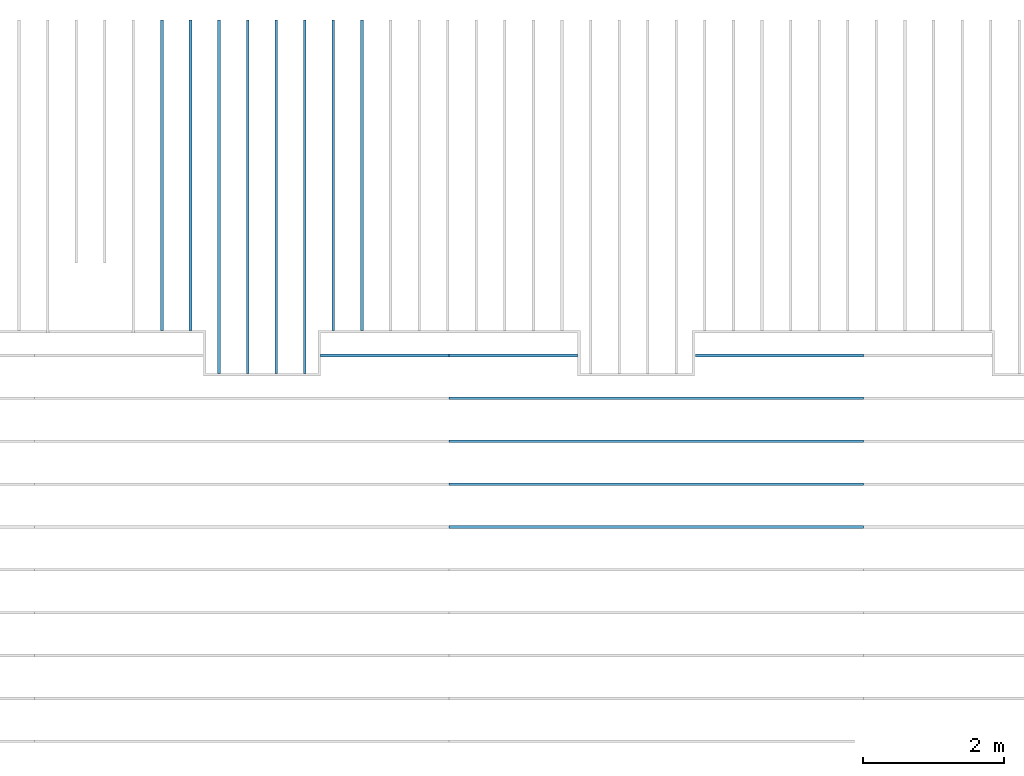
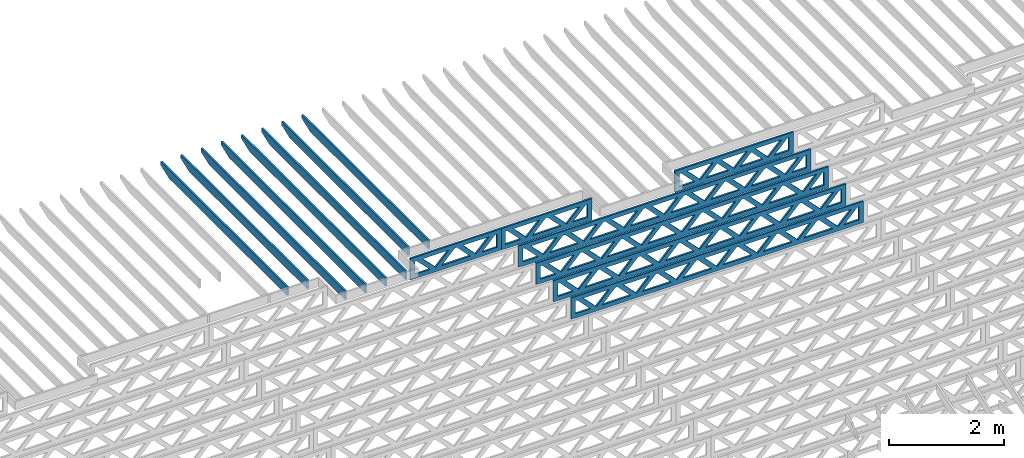
# One storey, part 10 of 18: 15 beams, 3 elements without a shape of their own.
"""IFC4 building model written with IfcOpenShell, lengths in feet."""

from ifc_helpers import new_model, entity, si_unit, converted_unit, derived_unit, direction, frame, frame_2d, origin, origin_2d_with_axis, place, context, subcontext, project, spatial, rectangle, extrude, clip, halfspace, source, transform, mapped, material, material_profile, profile_set, profile_usage, type_object, type_shapes, element, aggregate, save


model = new_model("IFC4")

# Units and contexts
model_context_1 = context("Model", 3, precision=0.0001, world=origin(), true_north=direction((6.12303176911189e-17, 1.0)))
model_context_2 = context("Model", 3, precision=0.0001, world=origin(), true_north=direction((6.12303176911189e-17, 1.0)))
body_context = subcontext(model_context_2, "Body", "Model", "MODEL_VIEW")
ifc_project = project(units=[converted_unit("LENGTHUNIT", "FOOT", entity("IfcRatioMeasure", 0.3048), si_unit("LENGTHUNIT", "METRE"), dimensions=[1, 0, 0, 0, 0, 0, 0]), converted_unit("AREAUNIT", "SQUARE FOOT", entity("IfcRatioMeasure", 0.09290304), si_unit("AREAUNIT", "SQUARE_METRE"), dimensions=[2, 0, 0, 0, 0, 0, 0]), converted_unit("VOLUMEUNIT", "CUBIC FOOT", entity("IfcRatioMeasure", 0.028316846592), si_unit("VOLUMEUNIT", "CUBIC_METRE"), dimensions=[3, 0, 0, 0, 0, 0, 0]), converted_unit("PLANEANGLEUNIT", "DEGREE", entity("IfcRatioMeasure", 0.0174532925199433), si_unit("PLANEANGLEUNIT", "RADIAN"), dimensions=[0, 0, 0, 0, 0, 0, 0]), si_unit("MASSUNIT", "GRAM", prefix="KILO"), derived_unit("MASSDENSITYUNIT", [(si_unit("MASSUNIT", "GRAM", prefix="KILO"), 1), (si_unit("LENGTHUNIT", "METRE"), -3)]), derived_unit("MOMENTOFINERTIAUNIT", [(si_unit("LENGTHUNIT", "METRE"), 4)]), si_unit("TIMEUNIT", "SECOND"), si_unit("FREQUENCYUNIT", "HERTZ"), si_unit("THERMODYNAMICTEMPERATUREUNIT", "DEGREE_CELSIUS"), derived_unit("THERMALTRANSMITTANCEUNIT", [(si_unit("MASSUNIT", "GRAM", prefix="KILO"), 1), (si_unit("THERMODYNAMICTEMPERATUREUNIT", "KELVIN"), -1), (si_unit("TIMEUNIT", "SECOND"), -3)]), derived_unit("VOLUMETRICFLOWRATEUNIT", [(si_unit("LENGTHUNIT", "METRE"), 3), (si_unit("TIMEUNIT", "SECOND"), -1)]), si_unit("ELECTRICCURRENTUNIT", "AMPERE"), si_unit("ELECTRICVOLTAGEUNIT", "VOLT"), si_unit("POWERUNIT", "WATT"), si_unit("FORCEUNIT", "NEWTON"), si_unit("ILLUMINANCEUNIT", "LUX"), si_unit("LUMINOUSFLUXUNIT", "LUMEN"), si_unit("LUMINOUSINTENSITYUNIT", "CANDELA"), derived_unit("USERDEFINED", [(si_unit("MASSUNIT", "GRAM", prefix="KILO"), -1), (si_unit("LENGTHUNIT", "METRE"), -2), (si_unit("TIMEUNIT", "SECOND"), 3), (si_unit("LUMINOUSFLUXUNIT", "LUMEN"), 1)]), derived_unit("LINEARVELOCITYUNIT", [(si_unit("LENGTHUNIT", "METRE"), 1), (si_unit("TIMEUNIT", "SECOND"), -1)]), si_unit("PRESSUREUNIT", "PASCAL"), derived_unit("USERDEFINED", [(si_unit("LENGTHUNIT", "METRE"), -2), (si_unit("MASSUNIT", "GRAM", prefix="KILO"), 1), (si_unit("TIMEUNIT", "SECOND"), -2)]), derived_unit("LINEARFORCEUNIT", [(si_unit("MASSUNIT", "GRAM", prefix="KILO"), 1), (si_unit("LENGTHUNIT", "METRE"), 1), (si_unit("TIMEUNIT", "SECOND"), -2), (si_unit("LENGTHUNIT", "METRE"), -1)]), derived_unit("PLANARFORCEUNIT", [(si_unit("MASSUNIT", "GRAM", prefix="KILO"), 1), (si_unit("LENGTHUNIT", "METRE"), 1), (si_unit("TIMEUNIT", "SECOND"), -2), (si_unit("LENGTHUNIT", "METRE"), -2)])], contexts=[model_context_1])

# Site, building, storey
site_placement = place(None, origin())
site = spatial("IfcSite", under=ifc_project, at=site_placement, CompositionType="ELEMENT")
building_placement = place(site_placement, origin())
building = spatial("IfcBuilding", under=site, at=building_placement, CompositionType="ELEMENT")
storey_placement = place(building_placement, frame((0.0, 0.0, 30.4375000000082)))
storey = spatial("IfcBuildingStorey", under=building, at=storey_placement, Name="ROOF", CompositionType="ELEMENT", Elevation=30.4375000000082)

# Assembly, beam
assembly_1_placement = place(storey_placement, origin())
assembly_1 = element("IfcElementAssembly", 1, at=assembly_1_placement, inside=storey, Name="Structural Beam System:Structural Framing System", ObjectType="Structural Beam System:Structural Framing System", AssemblyPlace="NOTDEFINED", PredefinedType="BEAM_GRID")
ifc_material_1 = material(Name="WOOD TRUSS", Category="Materials")
ifc_material_profile_1 = material_profile(ifc_material_1, rectangle(XDim=1.73473973950632, YDim=0.125, at=origin_2d_with_axis()))
ifc_material_profile_2 = material_profile(ifc_material_1, rectangle(XDim=1.73473973950633, YDim=0.125, at=frame_2d((-1.11022302462516e-16, 0.0), x_axis=(1.0, 0.0))))
ifc_material_profile_3 = material_profile(ifc_material_1, rectangle(XDim=1.73473973950632, YDim=0.125, at=origin_2d_with_axis()))
ifc_material_profile_4 = material_profile(ifc_material_1, rectangle(XDim=1.73473973950633, YDim=0.125, at=origin_2d_with_axis()))
ifc_material_profile_5 = material_profile(ifc_material_1, rectangle(XDim=1.73473973950632, YDim=0.125, at=frame_2d((-5.55111512312578e-17, 0.0), x_axis=(1.0, 0.0))))
ifc_material_profile_6 = material_profile(ifc_material_1, rectangle(XDim=1.73473973950633, YDim=0.125, at=frame_2d((-2.77555756156289e-16, 0.0), x_axis=(1.0, 0.0))))
ifc_material_profile_7 = material_profile(ifc_material_1, rectangle(XDim=1.73473973950632, YDim=0.125, at=frame_2d((-4.9960036108132e-16, 0.0), x_axis=(1.0, 0.0))))
ifc_material_profile_8 = material_profile(ifc_material_1, rectangle(XDim=1.73473973950633, YDim=0.125, at=frame_2d((4.44089209850063e-16, 0.0), x_axis=(1.0, 0.0))))
ifc_material_profile_9 = material_profile(ifc_material_1, rectangle(XDim=1.73473973950632, YDim=0.125, at=origin_2d_with_axis()))
ifc_material_profile_10 = material_profile(ifc_material_1, rectangle(XDim=1.73473973950633, YDim=0.125, at=frame_2d((-4.9960036108132e-16, 0.0), x_axis=(1.0, 0.0))))
ifc_material_profile_11 = material_profile(ifc_material_1, rectangle(XDim=0.291666666666664, YDim=0.125, at=frame_2d((-2.77555756156289e-17, 0.0), x_axis=(1.0, 0.0))))
ifc_material_profile_12 = material_profile(ifc_material_1, rectangle(XDim=0.291666666666628, YDim=0.124999999999995, at=frame_2d((-5.55111512312578e-17, 0.0), x_axis=(1.0, 0.0))))
ifc_material_profile_13 = material_profile(ifc_material_1, rectangle(XDim=0.916666666666666, YDim=0.125000000000003, at=frame_2d((-2.77555756156289e-17, 0.0), x_axis=(1.0, 0.0))))
ifc_material_profile_14 = material_profile(ifc_material_1, rectangle(XDim=0.916666666666651, YDim=0.125, at=frame_2d((-2.77555756156289e-17, 0.0), x_axis=(1.0, 0.0))))
ifc_profile_set_1 = profile_set([ifc_material_profile_1, ifc_material_profile_2, ifc_material_profile_3, ifc_material_profile_4, ifc_material_profile_5, ifc_material_profile_6, ifc_material_profile_7, ifc_material_profile_8, ifc_material_profile_9, ifc_material_profile_10, ifc_material_profile_11, ifc_material_profile_12, ifc_material_profile_13, ifc_material_profile_14])
ifc_profile_usage_1 = profile_usage(ifc_profile_set_1, cardinal=8)
beam_type_1 = type_object("IfcBeamType", PredefinedType="BEAM", material=ifc_profile_set_1)
shared_shape_1 = source(origin(), body_context, "Body", "SweptSolid", [
    extrude(rectangle(XDim=1.73473973950632, YDim=0.125, at=frame_2d((5.55111512312578e-17, 0.0), x_axis=(1.0, 0.0))), frame((1.8533931188195, 0.0, 0.101118361020515), z_axis=(0.720569184836762, 0.0, -0.693383046997606), x_axis=(0.693383046997606, 0.0, 0.720569184836762)), (0.0, 0.0, 1.0), 0.291666666666667),
    extrude(rectangle(XDim=1.73473973950633, YDim=0.125, at=frame_2d((-1.11022302462516e-16, 0.0), x_axis=(1.0, 0.0))), frame((0.603107245146231, 0.0, -0.101118361020454), z_axis=(0.720569184836758, 0.0, 0.69338304699761), x_axis=(0.69338304699761, 0.0, -0.720569184836758)), (0.0, 0.0, 1.0), 0.291666666666667),
    extrude(rectangle(XDim=1.73473973950632, YDim=0.125, at=frame_2d((-5.55111512312578e-17, 0.0), x_axis=(1.0, 0.0))), frame((-0.81327325738963, 0.0, 0.101118361020554), z_axis=(0.720569184836762, 0.0, -0.693383046997606), x_axis=(0.693383046997606, 0.0, 0.720569184836762)), (0.0, 0.0, 1.0), 0.291666666666667),
    extrude(rectangle(XDim=1.73473973950633, YDim=0.125, at=frame_2d((-1.66533453693773e-16, 0.0), x_axis=(1.0, 0.0))), frame((-2.0635591310629, 0.0, -0.101118361020415), z_axis=(0.720569184836758, 0.0, 0.69338304699761), x_axis=(0.69338304699761, 0.0, -0.720569184836758)), (0.0, 0.0, 1.0), 0.291666666666666),
    extrude(rectangle(XDim=0.291666666666664, YDim=0.125, at=frame_2d((-2.77555756156289e-17, 0.0), x_axis=(1.0, 0.0))), frame((-2.99999985477115, 0.0, 0.604166666666611), z_axis=(1.0, 0.0, 0.0), x_axis=(0.0, 0.0, -1.0)), (0.0, 0.0, 1.0), 5.99999970954229),
    extrude(rectangle(XDim=0.291666666666628, YDim=0.124999999999995, at=frame_2d((-5.55111512312578e-17, 0.0), x_axis=(1.0, 0.0))), frame((-2.99999985477093, 0.0, -0.604166666666693), z_axis=(1.0, 0.0, 0.0), x_axis=(0.0, 0.0, -1.0)), (0.0, 0.0, 1.0), 5.99999970954208),
    extrude(rectangle(XDim=0.916666666666666, YDim=0.125000000000003, at=frame_2d((-2.77555756156289e-17, 0.0), x_axis=(1.0, 0.0))), frame((2.70833318810446, 0.0, 0.0), z_axis=(1.0, 0.0, 0.0), x_axis=(0.0, 0.0, -1.0)), (0.0, 0.0, 1.0), 0.291666666666687),
    extrude(rectangle(XDim=0.916666666666651, YDim=0.125, at=frame_2d((-2.77555756156289e-17, 0.0), x_axis=(1.0, 0.0))), frame((-2.99999985477115, 0.0, 0.0), z_axis=(1.0, 0.0, 0.0), x_axis=(0.0, 0.0, -1.0)), (0.0, 0.0, 1.0), 0.291666666666687),
])
type_shapes(beam_type_1, [shared_shape_1])
beam_1_placement = place(assembly_1_placement, frame((-180.738160630791, 957.861934882651, 0.749999999991608), z_axis=(0.0, 0.0, 1.0), x_axis=(-1.0, 0.0, 0.0)))
beam_1 = element("IfcBeam", 2, at=beam_1_placement, type_object=beam_type_1, material=ifc_profile_usage_1, PredefinedType="BEAM", context=body_context, shape_type="MappedRepresentation", body=[
    mapped(shared_shape_1, transform((0.0, 0.0, 0.0), scale=1.0)),
])

# Assembly, beams
assembly_2_placement = place(storey_placement, origin())
assembly_2 = element("IfcElementAssembly", 3, at=assembly_2_placement, inside=storey, Name="Structural Beam System:Structural Framing System", ObjectType="Structural Beam System:Structural Framing System", AssemblyPlace="NOTDEFINED", PredefinedType="BEAM_GRID")
ifc_material_2 = material(Name="2X ROOF JOISTS - EXT. STAIN-1 - SEE LIFE SAFETY", Category="Materials")
ifc_material_profile_15 = material_profile(ifc_material_2, rectangle(XDim=0.604166666666667, YDim=0.125000000000011, at=frame_2d((0.0, 0.0), x_axis=(0.0, 1.0))))
ifc_profile_set_2 = profile_set([ifc_material_profile_15])
ifc_profile_usage_2 = profile_usage(ifc_profile_set_2, cardinal=8)
beam_type_2 = type_object("IfcBeamType", PredefinedType="BEAM", material=ifc_profile_set_2)
shared_shape_2 = source(origin(), body_context, "Body", "Clipping", [
    clip(extrude(rectangle(XDim=0.604166666666667, YDim=0.125000000000011, at=frame_2d((0.0, 0.0), x_axis=(0.0, 1.0))), frame((-8.24296473987818, 0.0, 0.0), z_axis=(1.0, 0.0, 0.0), x_axis=(0.0, 1.0, 0.0)), (0.0, 0.0, 1.0), 16.4859294797564), halfspace(frame((-7.26989982048795, -0.0625000000000026, -0.30208333333334), z_axis=(-0.34202014332567, 0.0, -0.939692620785908), x_axis=(0.0, 1.0, 0.0)), False)),
])
type_shapes(beam_type_2, [shared_shape_2])
beam_2_placement = place(assembly_2_placement, frame((-193.133993818795, 965.271566289195, 1.07291666665831), z_axis=(0.0, 0.0, 1.0), x_axis=(0.0, -1.0, 0.0)))
beam_2 = element("IfcBeam", 4, at=beam_2_placement, type_object=beam_type_2, material=ifc_profile_usage_2, PredefinedType="BEAM", context=body_context, shape_type="MappedRepresentation", body=[
    mapped(shared_shape_2, transform((0.0, 0.0, 0.0), scale=1.0)),
])
ifc_profile_usage_3 = profile_usage(ifc_profile_set_2, cardinal=8)
beam_3_placement = place(assembly_2_placement, frame((-190.467327152128, 965.271566289195, 1.07291666665831), z_axis=(0.0, 0.0, 1.0), x_axis=(0.0, -1.0, 0.0)))
beam_3 = element("IfcBeam", 5, at=beam_3_placement, type_object=beam_type_2, material=ifc_profile_usage_3, PredefinedType="BEAM", context=body_context, shape_type="MappedRepresentation", body=[
    mapped(shared_shape_2, transform((0.0, 0.0, 0.0), scale=1.0)),
])
ifc_profile_usage_4 = profile_usage(ifc_profile_set_2, cardinal=8)
beam_4_placement = place(assembly_2_placement, frame((-191.800660485462, 965.271566289195, 1.07291666665831), z_axis=(0.0, 0.0, 1.0), x_axis=(0.0, -1.0, 0.0)))
beam_4 = element("IfcBeam", 6, at=beam_4_placement, type_object=beam_type_2, material=ifc_profile_usage_4, PredefinedType="BEAM", context=body_context, shape_type="MappedRepresentation", body=[
    mapped(shared_shape_2, transform((0.0, 0.0, 0.0), scale=1.0)),
])
ifc_profile_usage_5 = profile_usage(ifc_profile_set_2, cardinal=8)
beam_5_placement = place(assembly_2_placement, frame((-194.467327152128, 965.271566289195, 1.07291666665831), z_axis=(0.0, 0.0, 1.0), x_axis=(0.0, -1.0, 0.0)))
beam_5 = element("IfcBeam", 7, at=beam_5_placement, type_object=beam_type_2, material=ifc_profile_usage_5, PredefinedType="BEAM", context=body_context, shape_type="MappedRepresentation", body=[
    mapped(shared_shape_2, transform((0.0, 0.0, 0.0), scale=1.0)),
])
ifc_profile_usage_6 = profile_usage(ifc_profile_set_2, cardinal=8)
beam_type_3 = type_object("IfcBeamType", PredefinedType="BEAM", material=ifc_profile_set_2)
shared_shape_3 = source(origin(), body_context, "Body", "Clipping", [
    clip(extrude(rectangle(XDim=0.604166666666667, YDim=0.125000000000011, at=frame_2d((0.0, 0.0), x_axis=(0.0, 1.0))), frame((-7.24296484470017, 0.0, 0.0), z_axis=(1.0, 0.0, 0.0), x_axis=(0.0, 1.0, 0.0)), (0.0, 0.0, 1.0), 14.4859296894003), halfspace(frame((-6.26989992530994, -0.0625000000000026, -0.30208333333334), z_axis=(-0.34202014332567, 0.0, -0.939692620785908), x_axis=(0.0, 1.0, 0.0)), False)),
])
type_shapes(beam_type_3, [shared_shape_3])
beam_6_placement = place(assembly_2_placement, frame((-197.133993818795, 966.271566184373, 1.07291666665831), z_axis=(0.0, 0.0, 1.0), x_axis=(0.0, -1.0, 0.0)))
beam_6 = element("IfcBeam", 8, at=beam_6_placement, type_object=beam_type_3, material=ifc_profile_usage_6, PredefinedType="BEAM", context=body_context, shape_type="MappedRepresentation", body=[
    mapped(shared_shape_3, transform((0.0, 0.0, 0.0), scale=1.0)),
])
ifc_profile_usage_7 = profile_usage(ifc_profile_set_2, cardinal=8)
beam_type_4 = type_object("IfcBeamType", PredefinedType="BEAM", material=ifc_profile_set_2)
shared_shape_4 = source(origin(), body_context, "Body", "Clipping", [
    clip(extrude(rectangle(XDim=0.604166666666667, YDim=0.125000000000011, at=frame_2d((0.0, 0.0), x_axis=(0.0, 1.0))), frame((-7.2429650122013, 0.0, 0.0), z_axis=(1.0, 0.0, 0.0), x_axis=(0.0, 1.0, 0.0)), (0.0, 0.0, 1.0), 14.4859300244026), halfspace(frame((-6.26990009281107, -0.0625000000000026, -0.30208333333334), z_axis=(-0.34202014332567, 0.0, -0.939692620785908), x_axis=(0.0, 1.0, 0.0)), False)),
])
type_shapes(beam_type_4, [shared_shape_4])
beam_7_placement = place(assembly_2_placement, frame((-195.800660485462, 966.271566016872, 1.07291666665831), z_axis=(0.0, 0.0, 1.0), x_axis=(0.0, -1.0, 0.0)))
beam_7 = element("IfcBeam", 9, at=beam_7_placement, type_object=beam_type_4, material=ifc_profile_usage_7, PredefinedType="BEAM", context=body_context, shape_type="MappedRepresentation", body=[
    mapped(shared_shape_4, transform((0.0, 0.0, 0.0), scale=1.0)),
])
ifc_profile_usage_8 = profile_usage(ifc_profile_set_2, cardinal=8)
beam_type_5 = type_object("IfcBeamType", PredefinedType="BEAM", material=ifc_profile_set_2)
shared_shape_5 = source(origin(), body_context, "Body", "Clipping", [
    clip(extrude(rectangle(XDim=0.604166666666667, YDim=0.125000000000011, at=frame_2d((0.0, 0.0), x_axis=(0.0, 1.0))), frame((-7.24296422111348, 0.0, 0.0), z_axis=(1.0, 0.0, 0.0), x_axis=(0.0, 1.0, 0.0)), (0.0, 0.0, 1.0), 14.485928442227), halfspace(frame((-6.26989930172326, -0.0625000000000026, -0.30208333333334), z_axis=(-0.34202014332567, 0.0, -0.939692620785908), x_axis=(0.0, 1.0, 0.0)), False)),
])
type_shapes(beam_type_5, [shared_shape_5])
beam_8_placement = place(assembly_2_placement, frame((-187.800660485462, 966.27156680796, 1.0729166666583), z_axis=(0.0, 0.0, 1.0), x_axis=(0.0, -1.0, 0.0)))
beam_8 = element("IfcBeam", 10, at=beam_8_placement, type_object=beam_type_5, material=ifc_profile_usage_8, PredefinedType="BEAM", context=body_context, shape_type="MappedRepresentation", body=[
    mapped(shared_shape_5, transform((0.0, 0.0, 0.0), scale=1.0)),
])
ifc_profile_usage_9 = profile_usage(ifc_profile_set_2, cardinal=8)
beam_type_6 = type_object("IfcBeamType", PredefinedType="BEAM", material=ifc_profile_set_2)
shared_shape_6 = source(origin(), body_context, "Body", "Clipping", [
    clip(extrude(rectangle(XDim=0.604166666666667, YDim=0.125000000000011, at=frame_2d((0.0, 0.0), x_axis=(0.0, 1.0))), frame((-7.24296437120802, 0.0, 0.0), z_axis=(1.0, 0.0, 0.0), x_axis=(0.0, 1.0, 0.0)), (0.0, 0.0, 1.0), 14.485928742416), halfspace(frame((-6.26989945181779, -0.0625000000000026, -0.30208333333334), z_axis=(-0.34202014332567, 0.0, -0.939692620785908), x_axis=(0.0, 1.0, 0.0)), False)),
])
type_shapes(beam_type_6, [shared_shape_6])
beam_9_placement = place(assembly_2_placement, frame((-189.133993818795, 966.271566657865, 1.0729166666583), z_axis=(0.0, 0.0, 1.0), x_axis=(0.0, -1.0, 0.0)))
beam_9 = element("IfcBeam", 11, at=beam_9_placement, type_object=beam_type_6, material=ifc_profile_usage_9, PredefinedType="BEAM", context=body_context, shape_type="MappedRepresentation", body=[
    mapped(shared_shape_6, transform((0.0, 0.0, 0.0), scale=1.0)),
])
aggregate(assembly_2, [beam_6, beam_7, beam_2, beam_3, beam_8, beam_9, beam_4, beam_5])

# Beam
ifc_profile_usage_10 = profile_usage(ifc_profile_set_1, cardinal=8)
beam_type_7 = type_object("IfcBeamType", PredefinedType="BEAM", material=ifc_profile_set_1)
shared_shape_7 = source(origin(), body_context, "Body", "SweptSolid", [
    extrude(rectangle(XDim=1.73473973950632, YDim=0.125, at=frame_2d((-5.55111512312578e-16, 0.0), x_axis=(1.0, 0.0))), frame((5.85339326404794, 0.0, 0.101118361020562), z_axis=(0.720569184836762, 0.0, -0.693383046997606), x_axis=(0.693383046997606, 0.0, 0.720569184836762)), (0.0, 0.0, 1.0), 0.291666666666667),
    extrude(rectangle(XDim=1.73473973950633, YDim=0.125, at=frame_2d((-4.9960036108132e-16, 0.0), x_axis=(1.0, 0.0))), frame((4.60310739037467, 0.0, -0.101118361020407), z_axis=(0.720569184836758, 0.0, 0.69338304699761), x_axis=(0.69338304699761, 0.0, -0.720569184836758)), (0.0, 0.0, 1.0), 0.291666666666667),
    extrude(rectangle(XDim=1.73473973950632, YDim=0.125, at=frame_2d((3.33066907387547e-16, 0.0), x_axis=(1.0, 0.0))), frame((3.18672659738144, 0.0, 0.101118361020562), z_axis=(0.720569184836762, 0.0, -0.693383046997606), x_axis=(0.693383046997606, 0.0, 0.720569184836762)), (0.0, 0.0, 1.0), 0.291666666666667),
    extrude(rectangle(XDim=1.73473973950633, YDim=0.125, at=frame_2d((-1.11022302462516e-16, 0.0), x_axis=(1.0, 0.0))), frame((1.93644072370817, 0.0, -0.101118361020407), z_axis=(0.720569184836758, 0.0, 0.69338304699761), x_axis=(0.69338304699761, 0.0, -0.720569184836758)), (0.0, 0.0, 1.0), 0.291666666666666),
    extrude(rectangle(XDim=1.73473973950632, YDim=0.125, at=frame_2d((5.55111512312578e-17, 0.0), x_axis=(1.0, 0.0))), frame((0.520059930714937, 0.0, 0.101118361020562), z_axis=(0.720569184836762, 0.0, -0.693383046997606), x_axis=(0.693383046997606, 0.0, 0.720569184836762)), (0.0, 0.0, 1.0), 0.291666666666667),
    extrude(rectangle(XDim=1.73473973950633, YDim=0.125, at=origin_2d_with_axis()), frame((-0.730225942958334, 0.0, -0.101118361020407), z_axis=(0.720569184836758, 0.0, 0.69338304699761), x_axis=(0.69338304699761, 0.0, -0.720569184836758)), (0.0, 0.0, 1.0), 0.291666666666666),
    extrude(rectangle(XDim=1.73473973950632, YDim=0.125, at=frame_2d((-5.55111512312578e-17, 0.0), x_axis=(1.0, 0.0))), frame((-2.14660673595157, 0.0, 0.101118361020562), z_axis=(0.720569184836762, 0.0, -0.693383046997606), x_axis=(0.693383046997606, 0.0, 0.720569184836762)), (0.0, 0.0, 1.0), 0.291666666666667),
    extrude(rectangle(XDim=1.73473973950633, YDim=0.125, at=frame_2d((-2.77555756156289e-16, 0.0), x_axis=(1.0, 0.0))), frame((-3.39689260962484, 0.0, -0.101118361020407), z_axis=(0.720569184836758, 0.0, 0.69338304699761), x_axis=(0.69338304699761, 0.0, -0.720569184836758)), (0.0, 0.0, 1.0), 0.291666666666666),
    extrude(rectangle(XDim=1.73473973950632, YDim=0.125, at=origin_2d_with_axis()), frame((-4.81327340261807, 0.0, 0.101118361020562), z_axis=(0.720569184836762, 0.0, -0.693383046997606), x_axis=(0.693383046997606, 0.0, 0.720569184836762)), (0.0, 0.0, 1.0), 0.291666666666667),
    extrude(rectangle(XDim=1.73473973950633, YDim=0.125, at=frame_2d((-4.9960036108132e-16, 0.0), x_axis=(1.0, 0.0))), frame((-6.06355927629134, 0.0, -0.101118361020407), z_axis=(0.720569184836758, 0.0, 0.69338304699761), x_axis=(0.69338304699761, 0.0, -0.720569184836758)), (0.0, 0.0, 1.0), 0.291666666666667),
    extrude(rectangle(XDim=1.73473973950632, YDim=0.125, at=frame_2d((-1.0547118733939e-15, 0.0), x_axis=(1.0, 0.0))), frame((8.52005993071445, 0.0, 0.101118361020506), z_axis=(0.720569184836761, 0.0, -0.693383046997607), x_axis=(0.693383046997607, 0.0, 0.720569184836761)), (0.0, 0.0, 1.0), 0.291666666666667),
    extrude(rectangle(XDim=1.73473973950633, YDim=0.125, at=origin_2d_with_axis()), frame((7.26977405704118, 0.0, -0.101118361020463), z_axis=(0.720569184836758, 0.0, 0.69338304699761), x_axis=(0.69338304699761, 0.0, -0.720569184836758)), (0.0, 0.0, 1.0), 0.291666666666667),
    extrude(rectangle(XDim=1.73473973950632, YDim=0.125, at=frame_2d((4.44089209850063e-16, 0.0), x_axis=(1.0, 0.0))), frame((-7.47994006928457, 0.0, 0.101118361020561), z_axis=(0.720569184836762, 0.0, -0.693383046997606), x_axis=(0.693383046997606, 0.0, 0.720569184836762)), (0.0, 0.0, 1.0), 0.291666666666666),
    extrude(rectangle(XDim=1.73473973950633, YDim=0.125, at=origin_2d_with_axis()), frame((-8.73022594295784, 0.0, -0.101118361020408), z_axis=(0.720569184836758, 0.0, 0.69338304699761), x_axis=(0.69338304699761, 0.0, -0.720569184836758)), (0.0, 0.0, 1.0), 0.291666666666666),
    extrude(rectangle(XDim=0.291666666666664, YDim=0.125, at=frame_2d((-2.77555756156289e-17, 0.0), x_axis=(1.0, 0.0))), frame((-9.66666666666609, 0.0, 0.604166666666611), z_axis=(1.0, 0.0, 0.0), x_axis=(0.0, 0.0, -1.0)), (0.0, 0.0, 1.0), 19.3333333333322),
    extrude(rectangle(XDim=0.291666666666628, YDim=0.124999999999995, at=frame_2d((-5.55111512312578e-17, 0.0), x_axis=(1.0, 0.0))), frame((-9.66666666666588, 0.0, -0.604166666666693), z_axis=(1.0, 0.0, 0.0), x_axis=(0.0, 0.0, -1.0)), (0.0, 0.0, 1.0), 19.333333333332),
    extrude(rectangle(XDim=0.916666666666666, YDim=0.125000000000003, at=frame_2d((-2.77555756156289e-17, 0.0), x_axis=(1.0, 0.0))), frame((9.3749999999994, 0.0, 0.0), z_axis=(1.0, 0.0, 0.0), x_axis=(0.0, 0.0, -1.0)), (0.0, 0.0, 1.0), 0.291666666666687),
    extrude(rectangle(XDim=0.916666666666651, YDim=0.125, at=frame_2d((-2.77555756156289e-17, 0.0), x_axis=(1.0, 0.0))), frame((-9.66666666666609, 0.0, 0.0), z_axis=(1.0, 0.0, 0.0), x_axis=(0.0, 0.0, -1.0)), (0.0, 0.0, 1.0), 0.291666666666687),
])
type_shapes(beam_type_7, [shared_shape_7])
beam_10_placement = place(assembly_1_placement, frame((-174.071493818896, 949.861934882651, 0.749999999991623), z_axis=(0.0, 0.0, 1.0), x_axis=(-1.0, 0.0, 0.0)))
beam_10 = element("IfcBeam", 12, at=beam_10_placement, type_object=beam_type_7, material=ifc_profile_usage_10, PredefinedType="BEAM", context=body_context, shape_type="MappedRepresentation", body=[
    mapped(shared_shape_7, transform((0.0, 0.0, 0.0), scale=1.0)),
])

ifc_profile_usage_11 = profile_usage(ifc_profile_set_1, cardinal=8)
beam_11_placement = place(assembly_1_placement, frame((-174.071493818896, 951.861934882651, 0.749999999991623), z_axis=(0.0, 0.0, 1.0), x_axis=(-1.0, 0.0, 0.0)))
beam_11 = element("IfcBeam", 13, at=beam_11_placement, type_object=beam_type_7, material=ifc_profile_usage_11, PredefinedType="BEAM", context=body_context, shape_type="MappedRepresentation", body=[
    mapped(shared_shape_7, transform((0.0, 0.0, 0.0), scale=1.0)),
])

ifc_profile_usage_12 = profile_usage(ifc_profile_set_1, cardinal=8)
beam_12_placement = place(assembly_1_placement, frame((-174.071493818896, 953.861934882651, 0.749999999991616), z_axis=(0.0, 0.0, 1.0), x_axis=(-1.0, 0.0, 0.0)))
beam_12 = element("IfcBeam", 14, at=beam_12_placement, type_object=beam_type_7, material=ifc_profile_usage_12, PredefinedType="BEAM", context=body_context, shape_type="MappedRepresentation", body=[
    mapped(shared_shape_7, transform((0.0, 0.0, 0.0), scale=1.0)),
])

ifc_profile_usage_13 = profile_usage(ifc_profile_set_1, cardinal=8)
beam_13_placement = place(assembly_1_placement, frame((-174.071493818896, 955.861934882651, 0.749999999991608), z_axis=(0.0, 0.0, 1.0), x_axis=(-1.0, 0.0, 0.0)))
beam_13 = element("IfcBeam", 15, at=beam_13_placement, type_object=beam_type_7, material=ifc_profile_usage_13, PredefinedType="BEAM", context=body_context, shape_type="MappedRepresentation", body=[
    mapped(shared_shape_7, transform((0.0, 0.0, 0.0), scale=1.0)),
])

# Assembly, beam
assembly_3_placement = place(storey_placement, origin())
assembly_3 = element("IfcElementAssembly", 16, at=assembly_3_placement, inside=storey, Name="Structural Beam System:Structural Framing System", ObjectType="Structural Beam System:Structural Framing System", AssemblyPlace="NOTDEFINED", PredefinedType="BEAM_GRID")
ifc_profile_usage_14 = profile_usage(ifc_profile_set_1, cardinal=8)
beam_type_8 = type_object("IfcBeamType", PredefinedType="BEAM", material=ifc_profile_set_1)
shared_shape_8 = source(origin(), body_context, "Body", "SweptSolid", [
    extrude(rectangle(XDim=1.73473973950632, YDim=0.125, at=frame_2d((5.55111512312578e-17, 0.0), x_axis=(1.0, 0.0))), frame((1.85339310373314, 0.0, 0.101118361020515), z_axis=(0.720569184836762, 0.0, -0.693383046997606), x_axis=(0.693383046997606, 0.0, 0.720569184836762)), (0.0, 0.0, 1.0), 0.291666666666667),
    extrude(rectangle(XDim=1.73473973950633, YDim=0.125, at=frame_2d((-1.11022302462516e-16, 0.0), x_axis=(1.0, 0.0))), frame((0.603107230059874, 0.0, -0.101118361020454), z_axis=(0.720569184836758, 0.0, 0.69338304699761), x_axis=(0.69338304699761, 0.0, -0.720569184836758)), (0.0, 0.0, 1.0), 0.291666666666667),
    extrude(rectangle(XDim=1.73473973950632, YDim=0.125, at=frame_2d((-5.55111512312578e-17, 0.0), x_axis=(1.0, 0.0))), frame((-0.813273242303273, 0.0, 0.101118361020554), z_axis=(0.720569184836762, 0.0, -0.693383046997606), x_axis=(0.693383046997606, 0.0, 0.720569184836762)), (0.0, 0.0, 1.0), 0.291666666666667),
    extrude(rectangle(XDim=1.73473973950633, YDim=0.125, at=frame_2d((-1.66533453693773e-16, 0.0), x_axis=(1.0, 0.0))), frame((-2.06355911597654, 0.0, -0.101118361020415), z_axis=(0.720569184836758, 0.0, 0.69338304699761), x_axis=(0.69338304699761, 0.0, -0.720569184836758)), (0.0, 0.0, 1.0), 0.291666666666666),
    extrude(rectangle(XDim=0.291666666666664, YDim=0.125, at=frame_2d((-2.77555756156289e-17, 0.0), x_axis=(1.0, 0.0))), frame((-2.99999983968479, 0.0, 0.604166666666611), z_axis=(1.0, 0.0, 0.0), x_axis=(0.0, 0.0, -1.0)), (0.0, 0.0, 1.0), 5.99999967936958),
    extrude(rectangle(XDim=0.291666666666628, YDim=0.124999999999995, at=frame_2d((-5.55111512312578e-17, 0.0), x_axis=(1.0, 0.0))), frame((-2.99999983968458, 0.0, -0.604166666666693), z_axis=(1.0, 0.0, 0.0), x_axis=(0.0, 0.0, -1.0)), (0.0, 0.0, 1.0), 5.99999967936937),
    extrude(rectangle(XDim=0.916666666666666, YDim=0.125000000000003, at=frame_2d((-2.77555756156289e-17, 0.0), x_axis=(1.0, 0.0))), frame((2.7083331730181, 0.0, 0.0), z_axis=(1.0, 0.0, 0.0), x_axis=(0.0, 0.0, -1.0)), (0.0, 0.0, 1.0), 0.291666666666687),
    extrude(rectangle(XDim=0.916666666666651, YDim=0.125, at=frame_2d((-2.77555756156289e-17, 0.0), x_axis=(1.0, 0.0))), frame((-2.99999983968479, 0.0, 0.0), z_axis=(1.0, 0.0, 0.0), x_axis=(0.0, 0.0, -1.0)), (0.0, 0.0, 1.0), 0.291666666666687),
])
type_shapes(beam_type_8, [shared_shape_8])
beam_14_placement = place(assembly_3_placement, frame((-186.738160325248, 957.861934882651, 0.749999999991601)))
beam_14 = element("IfcBeam", 17, at=beam_14_placement, type_object=beam_type_8, material=ifc_profile_usage_14, PredefinedType="BEAM", context=body_context, shape_type="MappedRepresentation", body=[
    mapped(shared_shape_8, transform((0.0, 0.0, 0.0), scale=1.0)),
])
aggregate(assembly_3, [beam_14])

# Beam
ifc_profile_usage_15 = profile_usage(ifc_profile_set_1, cardinal=8)
beam_type_9 = type_object("IfcBeamType", PredefinedType="BEAM", material=ifc_profile_set_1)
shared_shape_9 = source(origin(), body_context, "Body", "SweptSolid", [
    extrude(rectangle(XDim=1.73473973950632, YDim=0.125, at=origin_2d_with_axis()), frame((0.520059930714934, 0.0, 0.101118361020562), z_axis=(0.720569184836762, 0.0, -0.693383046997606), x_axis=(0.693383046997606, 0.0, 0.720569184836762)), (0.0, 0.0, 1.0), 0.291666666666667),
    extrude(rectangle(XDim=1.73473973950633, YDim=0.125, at=origin_2d_with_axis()), frame((-0.730225942958336, 0.0, -0.101118361020407), z_axis=(0.720569184836758, 0.0, 0.69338304699761), x_axis=(0.69338304699761, 0.0, -0.720569184836758)), (0.0, 0.0, 1.0), 0.291666666666666),
    extrude(rectangle(XDim=1.73473973950632, YDim=0.125, at=origin_2d_with_axis()), frame((2.77005983191593, 0.0, 0.101118361020514), z_axis=(0.720569184836762, 0.0, -0.693383046997606), x_axis=(0.693383046997606, 0.0, 0.720569184836762)), (0.0, 0.0, 1.0), 0.291666666666667),
    extrude(rectangle(XDim=1.73473973950633, YDim=0.125, at=frame_2d((-1.11022302462516e-16, 0.0), x_axis=(1.0, 0.0))), frame((1.51977395824266, 0.0, -0.101118361020455), z_axis=(0.720569184836758, 0.0, 0.69338304699761), x_axis=(0.69338304699761, 0.0, -0.720569184836758)), (0.0, 0.0, 1.0), 0.291666666666666),
    extrude(rectangle(XDim=1.73473973950632, YDim=0.125, at=frame_2d((-5.55111512312578e-17, 0.0), x_axis=(1.0, 0.0))), frame((-1.72993997048606, 0.0, 0.101118361020555), z_axis=(0.720569184836762, 0.0, -0.693383046997606), x_axis=(0.693383046997606, 0.0, 0.720569184836762)), (0.0, 0.0, 1.0), 0.291666666666667),
    extrude(rectangle(XDim=1.73473973950633, YDim=0.125, at=frame_2d((-2.77555756156289e-16, 0.0), x_axis=(1.0, 0.0))), frame((-2.98022584415933, 0.0, -0.101118361020414), z_axis=(0.720569184836758, 0.0, 0.69338304699761), x_axis=(0.69338304699761, 0.0, -0.720569184836758)), (0.0, 0.0, 1.0), 0.291666666666666),
    extrude(rectangle(XDim=0.291666666666664, YDim=0.125, at=frame_2d((-2.77555756156289e-17, 0.0), x_axis=(1.0, 0.0))), frame((-3.91666656786758, 0.0, 0.604166666666611), z_axis=(1.0, 0.0, 0.0), x_axis=(0.0, 0.0, -1.0)), (0.0, 0.0, 1.0), 7.83333313573516),
    extrude(rectangle(XDim=0.291666666666628, YDim=0.124999999999995, at=frame_2d((-5.55111512312578e-17, 0.0), x_axis=(1.0, 0.0))), frame((-3.91666656786737, 0.0, -0.604166666666693), z_axis=(1.0, 0.0, 0.0), x_axis=(0.0, 0.0, -1.0)), (0.0, 0.0, 1.0), 7.83333313573495),
    extrude(rectangle(XDim=0.916666666666666, YDim=0.125000000000003, at=frame_2d((-2.77555756156289e-17, 0.0), x_axis=(1.0, 0.0))), frame((3.62499990120089, 0.0, 0.0), z_axis=(1.0, 0.0, 0.0), x_axis=(0.0, 0.0, -1.0)), (0.0, 0.0, 1.0), 0.291666666666687),
    extrude(rectangle(XDim=0.916666666666651, YDim=0.125, at=frame_2d((-2.77555756156289e-17, 0.0), x_axis=(1.0, 0.0))), frame((-3.91666656786758, 0.0, 0.0), z_axis=(1.0, 0.0, 0.0), x_axis=(0.0, 0.0, -1.0)), (0.0, 0.0, 1.0), 0.291666666666687),
])
type_shapes(beam_type_9, [shared_shape_9])
beam_15_placement = place(assembly_1_placement, frame((-168.321493720097, 957.861934882651, 0.749999999991608), z_axis=(0.0, 0.0, 1.0), x_axis=(-1.0, 0.0, 0.0)))
beam_15 = element("IfcBeam", 18, at=beam_15_placement, type_object=beam_type_9, material=ifc_profile_usage_15, PredefinedType="BEAM", context=body_context, shape_type="MappedRepresentation", body=[
    mapped(shared_shape_9, transform((0.0, 0.0, 0.0), scale=1.0)),
])

aggregate(assembly_1, [beam_1, beam_10, beam_11, beam_12, beam_15, beam_13])

save(model, "model.ifc")
